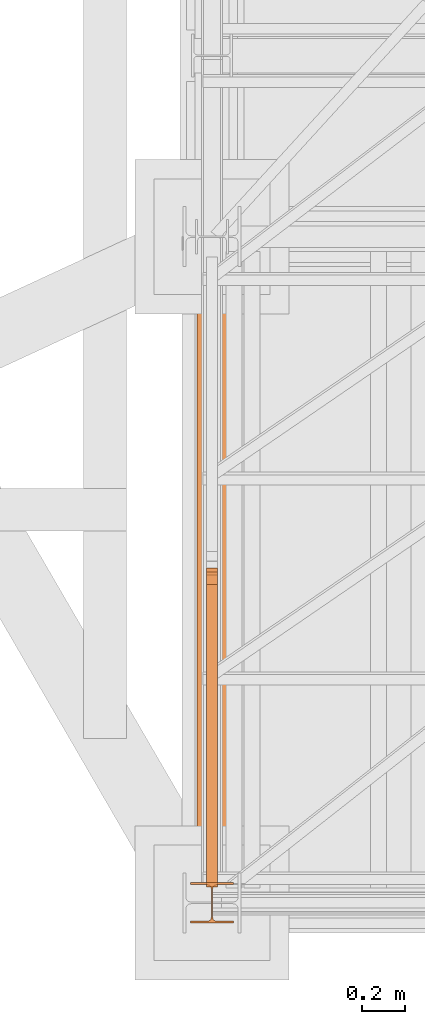
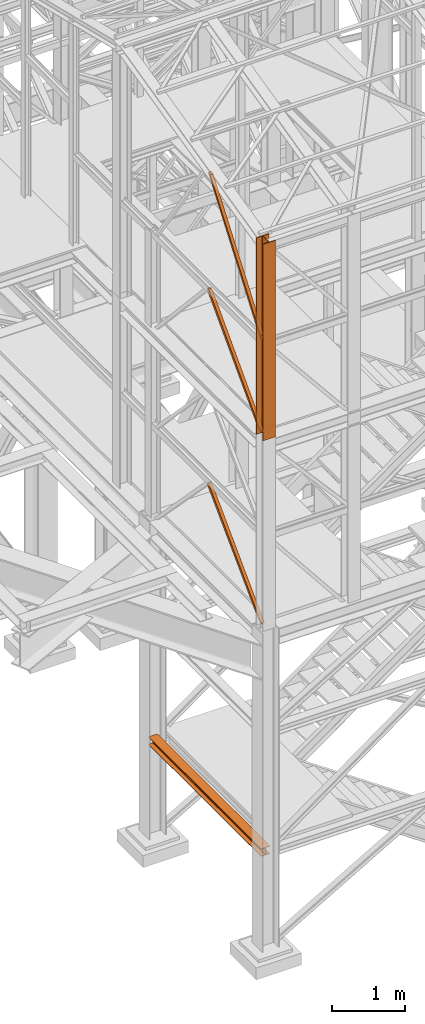
# One storey, part 3 of 208: 7 proxies.
"""IFC2X3 building model written with IfcOpenShell, lengths in millimetres."""

import ifcopenshell
import ifcopenshell.guid

model = None  # the IFC model being written
_history = None  # IfcOwnerHistory: only IFC2X3 demands one
_inside = {}  # id of a spatial element -> (the spatial element, [elements in it])
_under = {}  # id of a project, library or spatial element -> (it, [spatial elements below it])
_declared = {}  # id of a project -> (the project, [libraries it declares])
_typed = {}  # id of a type object -> (the type object, [elements of that type])
_made_of = {}  # id of a material, layer set ... -> (it, [elements and type objects made of it])


def new_model(schema):
    """Start an empty IFC model of exactly this schema.

    Asked for "IFC4X3", IfcOpenShell would pick the latest addendum, in which some entities
    have other attributes; the version numbers below select the first issue.
    IFC2X3 requires an IfcOwnerHistory on every rooted entity: one is made here for all.
    """
    global model, _history
    if schema == "IFC4X3":
        model = ifcopenshell.file(schema_version=(4, 3, 0, 0))
    else:
        model = ifcopenshell.file(schema=schema)
    _inside.clear()
    _under.clear()
    _declared.clear()
    _typed.clear()
    _made_of.clear()
    _history = None
    if model.schema == "IFC2X3":
        org = make("IfcOrganization", Name="unknown")
        user = make(
            "IfcPersonAndOrganization",
            ThePerson=make("IfcPerson", FamilyName="unknown"),
            TheOrganization=org,
        )
        app = make(
            "IfcApplication",
            ApplicationDeveloper=org,
            Version="unknown",
            ApplicationFullName="unknown",
            ApplicationIdentifier="unknown",
        )
        _history = make(
            "IfcOwnerHistory",
            OwningUser=user,
            OwningApplication=app,
            ChangeAction="ADDED",
            CreationDate=0,
        )
    return model


def make(cls, **values):
    """One entity of the class cls with the attributes given. An attribute that is None is left unset."""
    return model.create_entity(
        cls, **{name: value for name, value in values.items() if value is not None}
    )


def entity(cls, *values):
    """Any entity or typed value of the class cls, its attributes in the order of the schema. None: left unset."""
    e = model.create_entity(cls)
    for i, value in enumerate(values):
        if value is not None:
            e[i] = value
    return e


def rooted(cls, **values):
    """An entity with a GlobalId (a new one), such as an element, a storey or a relation."""
    return make(cls, GlobalId=ifcopenshell.guid.new(), OwnerHistory=_history, **values)


def si_unit(unit_type, name, prefix=None):
    """IfcSIUnit, for example si_unit("LENGTHUNIT", "METRE", prefix="MILLI")."""
    return make("IfcSIUnit", UnitType=unit_type, Prefix=prefix, Name=name)


def converted_unit(unit_type, name, factor, base, dimensions=None, offset=None):
    """IfcConversionBasedUnit, such as the inch: factor (a typed value) times the base unit."""
    return make(
        "IfcConversionBasedUnit"
        if offset is None
        else "IfcConversionBasedUnitWithOffset",
        ConversionOffset=offset,
        Dimensions=None
        if dimensions is None
        else entity("IfcDimensionalExponents", *dimensions),
        UnitType=unit_type,
        Name=name,
        ConversionFactor=make(
            "IfcMeasureWithUnit", ValueComponent=factor, UnitComponent=base
        ),
    )


def assignment(units):
    """IfcUnitAssignment: the units of a project."""
    return None if units is None else make("IfcUnitAssignment", Units=units)


def point(xyz):
    """IfcCartesianPoint."""
    return None if xyz is None else make("IfcCartesianPoint", Coordinates=xyz)


def direction(xyz):
    """IfcDirection."""
    return None if xyz is None else make("IfcDirection", DirectionRatios=xyz)


def frame(location, z_axis=None, x_axis=None):
    """IfcAxis2Placement3D, a coordinate frame: its origin and axes. An axis left out is left unset."""
    return make(
        "IfcAxis2Placement3D",
        Location=point(location),
        Axis=direction(z_axis),
        RefDirection=direction(x_axis),
    )


def origin():
    """The frame at (0, 0, 0) with its axes left unset."""
    return frame((0.0, 0.0, 0.0))


def origin_with_axes():
    """The frame at (0, 0, 0) with the z axis (0, 0, 1) and the x axis (1, 0, 0) written out."""
    return frame((0.0, 0.0, 0.0), z_axis=(0.0, 0.0, 1.0), x_axis=(1.0, 0.0, 0.0))


def place(relative_to, where):
    """IfcLocalPlacement: puts the frame where relative to a parent placement (None: the world)."""
    return make(
        "IfcLocalPlacement", PlacementRelTo=relative_to, RelativePlacement=where
    )


def context(
    kind, dimensions, precision=None, world=None, true_north=None, identifier=None
):
    """IfcGeometricRepresentationContext, for example the 3D "Model" context."""
    return make(
        "IfcGeometricRepresentationContext",
        ContextIdentifier=identifier,
        ContextType=kind,
        CoordinateSpaceDimension=dimensions,
        Precision=precision,
        WorldCoordinateSystem=world,
        TrueNorth=true_north,
    )


def subcontext(parent, identifier, kind, view, scale=None):
    """IfcGeometricRepresentationSubContext, for example "Body" below "Model"."""
    return make(
        "IfcGeometricRepresentationSubContext",
        ContextIdentifier=identifier,
        ContextType=kind,
        ParentContext=parent,
        TargetScale=scale,
        TargetView=view,
    )


def project(units=None, contexts=None):
    """IfcProject with its units and contexts."""
    return rooted(
        "IfcProject",
        Name="project",
        RepresentationContexts=contexts,
        UnitsInContext=assignment(units),
    )


def spatial(cls, under=None, at=None, **own):
    """A site, building, storey or space (cls), placed at a placement, below another one or the project."""
    s = rooted(cls, ObjectPlacement=at, **own)
    if under is not None:
        _under.setdefault(under.id(), (under, []))[1].append(s)
    return s


def faces_of(points, faces, orient=None, outer=None):
    """IfcFace entities. A face is a list of loops; a loop is a list of indices into points, from 0.

    orient and outer hold one flag for each loop. By default every Orientation is true, the
    first loop of a face is its IfcFaceOuterBound and the others are IfcFaceBound.
    """
    made = []
    for i, loops in enumerate(faces):
        bounds = []
        for j, loop in enumerate(loops):
            is_outer = j == 0 if outer is None else outer[i][j]
            bounds.append(
                make(
                    "IfcFaceOuterBound" if is_outer else "IfcFaceBound",
                    Bound=make("IfcPolyLoop", Polygon=[points[k] for k in loop]),
                    Orientation=True if orient is None else orient[i][j],
                )
            )
        made.append(make("IfcFace", Bounds=bounds))
    return made


def faceted_brep(points, faces, orient=None, outer=None, voids=None):
    """IfcFacetedBrep: a solid bounded by flat faces; with voids (closed shells), ...WithVoids."""
    shared = [point(p) for p in points]
    hull = make("IfcClosedShell", CfsFaces=faces_of(shared, faces, orient, outer))
    if voids is None:
        return make("IfcFacetedBrep", Outer=hull)
    return make(
        "IfcFacetedBrepWithVoids",
        Outer=hull,
        Voids=[
            make(cls, CfsFaces=faces_of(shared, fs, o, b)) for cls, fs, o, b in voids
        ],
    )


def shape(context_of_items, identifier, shape_type, items):
    """IfcShapeRepresentation: the items that make up one representation, for example the "Body"."""
    return make(
        "IfcShapeRepresentation",
        ContextOfItems=context_of_items,
        RepresentationIdentifier=identifier,
        RepresentationType=shape_type,
        Items=items,
    )


def made_of(thing, what):
    """Note that an element or type object is made of a material, layer set ...; save() writes the relation."""
    if what is not None:
        _made_of.setdefault(what.id(), (what, []))[1].append(thing)
    return thing


def element(
    cls,
    number,
    at=None,
    inside=None,
    cuts=None,
    type_object=None,
    material=None,
    context=None,
    identifier="Body",
    shape_type=None,
    held_by="IfcProductDefinitionShape",
    body=None,
    shapes=None,
    **own,
):
    """One element of the class cls, such as IfcWall. Its Tag is "e" and its number.

    at: its placement. inside: the storey or other place that contains it. cuts: it is an
    opening in that element (IfcRelVoidsElement). A single representation is given by context,
    identifier, shape_type and body (its items); several are given by shapes. held_by: the class
    of the entity that holds the representations. save() writes the other relations.
    """
    e = rooted(cls, Tag="e%d" % number, ObjectPlacement=at, **own)
    if body is not None:
        shapes = [shape(context, identifier, shape_type, body)]
    if shapes is not None:
        e.Representation = make(held_by, Representations=shapes)
    if inside is not None:
        _inside.setdefault(inside.id(), (inside, []))[1].append(e)
    if cuts is not None:
        rooted(
            "IfcRelVoidsElement", RelatingBuildingElement=cuts, RelatedOpeningElement=e
        )
    if type_object is not None:
        _typed.setdefault(type_object.id(), (type_object, []))[1].append(e)
    return made_of(e, material)


def aggregate(whole, parts):
    """IfcRelAggregates: a whole, such as a stair, and the parts it consists of."""
    return rooted("IfcRelAggregates", RelatingObject=whole, RelatedObjects=parts)


def save(model, path):
    """Write the relations noted so far, then the file.

    IfcRelAggregates (storeys below a building ...), IfcRelContainedInSpatialStructure (elements
    in a storey), IfcRelDefinesByType, IfcRelAssociatesMaterial and IfcRelDeclares: one each for
    every whole, place, type object, material and project.
    """
    for whole, parts in _under.values():
        aggregate(whole, parts)
    for where, things in _inside.values():
        rooted(
            "IfcRelContainedInSpatialStructure",
            RelatedElements=things,
            RelatingStructure=where,
        )
    for kind, things in _typed.values():
        rooted("IfcRelDefinesByType", RelatedObjects=things, RelatingType=kind)
    for what, things in _made_of.values():
        rooted("IfcRelAssociatesMaterial", RelatedObjects=things, RelatingMaterial=what)
    for by, libraries in _declared.values():
        rooted("IfcRelDeclares", RelatingContext=by, RelatedDefinitions=libraries)
    model.write(path)


model = new_model("IFC2X3")

# Units and contexts
model_context = context("Model", 3, precision=1e-05, world=origin())
plan_context = context("Plan", 3, precision=1e-05, world=origin())
body_context = subcontext(model_context, "Body", "Model", "MODEL_VIEW")
ifc_project = project(units=[si_unit("LENGTHUNIT", "METRE", prefix="MILLI"), converted_unit("PLANEANGLEUNIT", "DEGREE", entity("IfcPlaneAngleMeasure", 0.0174532925199433), si_unit("PLANEANGLEUNIT", "RADIAN"), dimensions=[0, 0, 0, 0, 0, 0, 0]), si_unit("AREAUNIT", "SQUARE_METRE"), si_unit("VOLUMEUNIT", "CUBIC_METRE")], contexts=[model_context, plan_context])

# Building, storey
building_placement = place(None, origin())
building = spatial("IfcBuilding", under=ifc_project, at=building_placement, CompositionType="COMPLEX")
storey_placement = place(building_placement, origin_with_axes())
storey = spatial("IfcBuildingStorey", under=building, at=storey_placement, Name="Geschoss", CompositionType="ELEMENT")

# Proxies
proxy_1_placement = place(storey_placement, frame((1128.922936086903, -25168.5743901279, 1433.489998909946), z_axis=(0.0, 0.0, 1.0), x_axis=(1.0, 0.0, 0.0)))
element("IfcBuildingElementProxy", 1, at=proxy_1_placement, inside=storey, context=body_context, shape_type="Brep", body=[
    faceted_brep([(0.01000000000067303, 3102.009999620019, 8.510002324581137), (0.01000000000067303, 3102.009999620019, 0.009999999999990905), (140.0100005960469, 3102.009999620019, 0.009999999999990905), (140.0100005960469, 3102.009999620019, 8.510002324581137), (84.76000038743086, 3102.009999620019, 8.510002324581137), (78.54945996612378, 3102.009999620019, 9.753034839630118), (74.00303279817172, 3102.009999620019, 14.2994648015499), (72.76000051595338, 3102.009999620019, 20.51000429153442), (72.76000051595338, 3102.009999620019, 112.5100007450581), (74.00303279817172, 3102.009999620019, 118.7205402350426), (78.54945996612378, 3102.009999620019, 123.2669664716721), (84.76000038743086, 3102.009999620019, 124.509998986721), (140.0100005960469, 3102.009999620019, 124.509998986721), (140.0100005960469, 3102.009999620019, 133.0100013113022), (0.01000000000067303, 3102.009999620019, 133.0100013113022), (0.01000000000067303, 3102.009999620019, 124.509998986721), (55.26000020861693, 3102.009999620019, 124.509998986721), (61.47054062992402, 3102.009999620019, 123.2669664716721), (66.01696779787608, 3102.009999620019, 118.7205402350426), (67.26000008009441, 3102.009999620019, 112.5100007450581), (67.26000008009441, 3102.009999620019, 20.51000429153442), (66.01696779787608, 3102.009999620019, 14.2994648015499), (61.47054062992402, 3102.009999620019, 9.753034839630118), (55.26000020861693, 3102.009999620019, 8.510002324581137), (0.01000000000067303, 3102.009999620019, 0.009999999999990905), (0.01000000000067303, 3102.009999620019, 8.510002324581137), (0.01000000000021828, 0.00999999999839929, 8.510002324581137), (0.01000000000021828, 0.00999999999839929, 0.009999999999990905), (140.0100005960469, 3102.009999620019, 0.009999999999990905), (0.01000000000067303, 3102.009999620019, 0.009999999999990905), (0.01000000000021828, 0.00999999999839929, 0.009999999999990905), (140.0100005960467, 0.00999999999839929, 0.009999999999990905), (140.0100005960469, 3102.009999620019, 8.510002324581137), (140.0100005960469, 3102.009999620019, 0.009999999999990905), (140.0100005960467, 0.00999999999839929, 0.009999999999990905), (140.0100005960467, 0.00999999999839929, 8.510002324581137), (84.76000038743086, 3102.009999620019, 8.510002324581137), (140.0100005960469, 3102.009999620019, 8.510002324581137), (140.0100005960467, 0.00999999999839929, 8.510002324581137), (84.76000038743041, 0.00999999999839929, 8.510002324581137), (78.54945996612378, 3102.009999620019, 9.753034839630118), (84.76000038743086, 3102.009999620019, 8.510002324581137), (84.76000038743041, 0.00999999999839929, 8.510002324581137), (78.54945996612332, 0.00999999999839929, 9.753034839630118), (74.00303279817172, 3102.009999620019, 14.2994648015499), (78.54945996612378, 3102.009999620019, 9.753034839630118), (78.54945996612332, 0.00999999999839929, 9.753034839630118), (74.00303279817126, 0.00999999999839929, 14.2994648015499), (72.76000051595338, 3102.009999620019, 20.51000429153442), (74.00303279817172, 3102.009999620019, 14.2994648015499), (74.00303279817126, 0.00999999999839929, 14.2994648015499), (72.76000051595292, 0.00999999999839929, 20.51000429153442), (72.76000051595338, 3102.009999620019, 112.5100007450581), (72.76000051595338, 3102.009999620019, 20.51000429153442), (72.76000051595292, 0.00999999999839929, 20.51000429153442), (72.76000051595292, 0.00999999999839929, 112.5100007450581), (74.00303279817172, 3102.009999620019, 118.7205402350426), (72.76000051595338, 3102.009999620019, 112.5100007450581), (72.76000051595292, 0.00999999999839929, 112.5100007450581), (74.00303279817126, 0.00999999999839929, 118.7205402350426), (78.54945996612378, 3102.009999620019, 123.2669664716721), (74.00303279817172, 3102.009999620019, 118.7205402350426), (74.00303279817126, 0.00999999999839929, 118.7205402350426), (78.54945996612332, 0.00999999999839929, 123.2669664716721), (84.76000038743086, 3102.009999620019, 124.509998986721), (78.54945996612378, 3102.009999620019, 123.2669664716721), (78.54945996612332, 0.00999999999839929, 123.2669664716721), (84.76000038743041, 0.00999999999839929, 124.509998986721), (140.0100005960469, 3102.009999620019, 124.509998986721), (84.76000038743086, 3102.009999620019, 124.509998986721), (84.76000038743041, 0.00999999999839929, 124.509998986721), (140.0100005960467, 0.00999999999839929, 124.509998986721), (140.0100005960469, 3102.009999620019, 133.0100013113022), (140.0100005960469, 3102.009999620019, 124.509998986721), (140.0100005960467, 0.00999999999839929, 124.509998986721), (140.0100005960467, 0.00999999999839929, 133.0100013113022), (0.01000000000067303, 3102.009999620019, 133.0100013113022), (140.0100005960469, 3102.009999620019, 133.0100013113022), (140.0100005960467, 0.00999999999839929, 133.0100013113022), (0.01000000000021828, 0.00999999999839929, 133.0100013113022), (0.01000000000067303, 3102.009999620019, 124.509998986721), (0.01000000000067303, 3102.009999620019, 133.0100013113022), (0.01000000000021828, 0.00999999999839929, 133.0100013113022), (0.01000000000021828, 0.00999999999839929, 124.509998986721), (55.26000020861693, 3102.009999620019, 124.509998986721), (0.01000000000067303, 3102.009999620019, 124.509998986721), (0.01000000000021828, 0.00999999999839929, 124.509998986721), (55.26000020861648, 0.00999999999839929, 124.509998986721), (61.47054062992402, 3102.009999620019, 123.2669664716721), (55.26000020861693, 3102.009999620019, 124.509998986721), (55.26000020861648, 0.00999999999839929, 124.509998986721), (61.47054062992356, 0.00999999999839929, 123.2669664716721), (66.01696779787608, 3102.009999620019, 118.7205402350426), (61.47054062992402, 3102.009999620019, 123.2669664716721), (61.47054062992356, 0.00999999999839929, 123.2669664716721), (66.01696779787562, 0.00999999999839929, 118.7205402350426), (67.26000008009441, 3102.009999620019, 112.5100007450581), (66.01696779787608, 3102.009999620019, 118.7205402350426), (66.01696779787562, 0.00999999999839929, 118.7205402350426), (67.26000008009396, 0.00999999999839929, 112.5100007450581), (67.26000008009441, 3102.009999620019, 20.51000429153442), (67.26000008009441, 3102.009999620019, 112.5100007450581), (67.26000008009396, 0.00999999999839929, 112.5100007450581), (67.26000008009396, 0.00999999999839929, 20.51000429153442), (66.01696779787608, 3102.009999620019, 14.2994648015499), (67.26000008009441, 3102.009999620019, 20.51000429153442), (67.26000008009396, 0.00999999999839929, 20.51000429153442), (66.01696779787562, 0.00999999999839929, 14.2994648015499), (61.47054062992402, 3102.009999620019, 9.753034839630118), (66.01696779787608, 3102.009999620019, 14.2994648015499), (66.01696779787562, 0.00999999999839929, 14.2994648015499), (61.47054062992356, 0.00999999999839929, 9.753034839630118), (55.26000020861693, 3102.009999620019, 8.510002324581137), (61.47054062992402, 3102.009999620019, 9.753034839630118), (61.47054062992356, 0.00999999999839929, 9.753034839630118), (55.26000020861648, 0.00999999999839929, 8.510002324581137), (0.01000000000067303, 3102.009999620019, 8.510002324581137), (55.26000020861693, 3102.009999620019, 8.510002324581137), (55.26000020861648, 0.00999999999839929, 8.510002324581137), (0.01000000000021828, 0.00999999999839929, 8.510002324581137), (0.01000000000021828, 0.00999999999839929, 8.510002324581137), (55.26000020861648, 0.00999999999839929, 8.510002324581137), (61.47054062992356, 0.00999999999839929, 9.753034839630118), (66.01696779787562, 0.00999999999839929, 14.2994648015499), (67.26000008009396, 0.00999999999839929, 20.51000429153442), (67.26000008009396, 0.00999999999839929, 112.5100007450581), (66.01696779787562, 0.00999999999839929, 118.7205402350426), (61.47054062992356, 0.00999999999839929, 123.2669664716721), (55.26000020861648, 0.00999999999839929, 124.509998986721), (0.01000000000021828, 0.00999999999839929, 124.509998986721), (0.01000000000021828, 0.00999999999839929, 133.0100013113022), (140.0100005960467, 0.00999999999839929, 133.0100013113022), (140.0100005960467, 0.00999999999839929, 124.509998986721), (84.76000038743041, 0.00999999999839929, 124.509998986721), (78.54945996612332, 0.00999999999839929, 123.2669664716721), (74.00303279817126, 0.00999999999839929, 118.7205402350426), (72.76000051595292, 0.00999999999839929, 112.5100007450581), (72.76000051595292, 0.00999999999839929, 20.51000429153442), (74.00303279817126, 0.00999999999839929, 14.2994648015499), (78.54945996612332, 0.00999999999839929, 9.753034839630118), (84.76000038743041, 0.00999999999839929, 8.510002324581137), (140.0100005960467, 0.00999999999839929, 8.510002324581137), (140.0100005960467, 0.00999999999839929, 0.009999999999990905), (0.01000000000021828, 0.00999999999839929, 0.009999999999990905)], [[[0, 1, 2, 3, 4, 5, 6, 7, 8, 9, 10, 11, 12, 13, 14, 15, 16, 17, 18, 19, 20, 21, 22, 23]], [[24, 25, 26, 27]], [[28, 29, 30, 31]], [[32, 33, 34, 35]], [[36, 37, 38, 39]], [[40, 41, 42, 43]], [[44, 45, 46, 47]], [[48, 49, 50, 51]], [[52, 53, 54, 55]], [[56, 57, 58, 59]], [[60, 61, 62, 63]], [[64, 65, 66, 67]], [[68, 69, 70, 71]], [[72, 73, 74, 75]], [[76, 77, 78, 79]], [[80, 81, 82, 83]], [[84, 85, 86, 87]], [[88, 89, 90, 91]], [[92, 93, 94, 95]], [[96, 97, 98, 99]], [[100, 101, 102, 103]], [[104, 105, 106, 107]], [[108, 109, 110, 111]], [[112, 113, 114, 115]], [[116, 117, 118, 119]], [[120, 121, 122, 123, 124, 125, 126, 127, 128, 129, 130, 131, 132, 133, 134, 135, 136, 137, 138, 139, 140, 141, 142, 143]]], orient=[[False], [False], [False], [False], [False], [False], [False], [False], [False], [False], [False], [False], [False], [False], [False], [False], [False], [False], [False], [False], [False], [False], [False], [False], [False], [False]]),
])
proxy_2_placement = place(storey_placement, frame((1098.254967038543, -25267.57439657637, 8484.990002086155), z_axis=(0.0, 0.0, 1.0), x_axis=(1.0, 0.0, 0.0)))
element("IfcBuildingElementProxy", 2, at=proxy_2_placement, inside=storey, context=body_context, shape_type="Brep", body=[
    faceted_brep([(0.009999999999990905, 190.010021192018, 3300.392426689976), (200.0100029802322, 190.010021192018, 3300.392426689976), (200.0100029802322, 180.0100232781806, 3300.392426689976), (121.2600035762787, 180.0100158276, 3300.392426689976), (111.9441915473342, 178.1454707803168, 3300.392426689976), (105.1245498640835, 171.3258277000823, 3300.392426689976), (103.2600015571713, 162.0100166024604, 3300.392426689976), (103.2600015571713, 28.01000581401968, 3300.392426689976), (105.1245498640835, 18.69419471639776, 3300.392426689976), (111.9441915473342, 11.87455163616323, 3300.392426689976), (121.2600035762787, 10.01000658888006, 3300.392426689976), (200.0100029802322, 10.01000658888006, 3300.392426689976), (200.0100029802322, 0.01000867504262715, 3300.392426689976), (0.009999999999990905, 0.01000867504262715, 3300.392426689976), (0.009999999999990905, 10.01000658888006, 3300.392426689976), (78.75999940395354, 10.01000658888006, 3300.392426689976), (88.07581143289804, 11.87455163616323, 3300.392426689976), (94.8954531161487, 18.69419471639776, 3300.392426689976), (96.76000142306088, 28.01000581401968, 3300.392426689976), (96.76000142306088, 162.0100166024604, 3300.392426689976), (94.8954531161487, 171.3258277000823, 3300.392426689976), (88.07581143289804, 178.1454707803168, 3300.392426689976), (78.75999940395354, 180.0100158276, 3300.392426689976), (0.009999999999990905, 180.0100232781806, 3300.392426689976), (200.0100029802322, 190.010021192018, 3300.392426689976), (0.009999999999990905, 190.010021192018, 3300.392426689976), (0.009999999999990905, 190.0100125169738, 0.01000000000021828), (200.0100029802322, 190.0100125169738, 0.01000000000021828), (200.0100029802322, 180.0100232781806, 3300.392426689976), (200.0100029802322, 190.010021192018, 3300.392426689976), (200.0100029802322, 190.0100125169738, 0.01000000000021828), (200.0100029802322, 180.0100146031364, 0.01000000000021828), (121.2600035762787, 180.0100158276, 3300.392426689976), (200.0100029802322, 180.0100232781806, 3300.392426689976), (200.0100029802322, 180.0100146031364, 0.01000000000021828), (121.2600035762787, 180.0100071525558, 0.01000000000021828), (111.9441915473342, 178.1454707803168, 3300.392426689976), (121.2600035762787, 180.0100158276, 3300.392426689976), (121.2600035762787, 180.0100071525558, 0.01000000000021828), (111.9441915473342, 178.1454621052726, 0.01000000000021828), (105.1245498640835, 171.3258277000823, 3300.392426689976), (111.9441915473342, 178.1454707803168, 3300.392426689976), (111.9441915473342, 178.1454621052726, 0.01000000000021828), (105.1245498640835, 171.3258190250381, 0.01000000000021828), (103.2600015571713, 162.0100166024604, 3300.392426689976), (105.1245498640835, 171.3258277000823, 3300.392426689976), (105.1245498640835, 171.3258190250381, 0.01000000000021828), (103.2600015571713, 162.0100079274162, 0.01000000000021828), (103.2600015571713, 28.01000581401968, 3300.392426689976), (103.2600015571713, 162.0100166024604, 3300.392426689976), (103.2600015571713, 162.0100079274162, 0.01000000000021828), (103.2600015571713, 28.00999713897545, 0.01000000000021828), (105.1245498640835, 18.69419471639776, 3300.392426689976), (103.2600015571713, 28.01000581401968, 3300.392426689976), (103.2600015571713, 28.00999713897545, 0.01000000000021828), (105.1245498640835, 18.69418604135353, 0.01000000000021828), (111.9441915473342, 11.87455163616323, 3300.392426689976), (105.1245498640835, 18.69419471639776, 3300.392426689976), (105.1245498640835, 18.69418604135353, 0.01000000000021828), (111.9441915473342, 11.87454296111901, 0.01000000000021828), (121.2600035762787, 10.01000658888006, 3300.392426689976), (111.9441915473342, 11.87455163616323, 3300.392426689976), (111.9441915473342, 11.87454296111901, 0.01000000000021828), (121.2600035762787, 10.00999791383583, 0.01000000000021828), (200.0100029802322, 10.01000658888006, 3300.392426689976), (121.2600035762787, 10.01000658888006, 3300.392426689976), (121.2600035762787, 10.00999791383583, 0.01000000000021828), (200.0100029802322, 10.00999791383583, 0.01000000000021828), (200.0100029802322, 0.01000867504262715, 3300.392426689976), (200.0100029802322, 10.01000658888006, 3300.392426689976), (200.0100029802322, 10.00999791383583, 0.01000000000021828), (200.0100029802322, 0.00999999999839929, 0.01000000000021828), (0.009999999999990905, 0.01000867504262715, 3300.392426689976), (200.0100029802322, 0.01000867504262715, 3300.392426689976), (200.0100029802322, 0.00999999999839929, 0.01000000000021828), (0.009999999999990905, 0.00999999999839929, 0.01000000000021828), (0.009999999999990905, 10.01000658888006, 3300.392426689976), (0.009999999999990905, 0.01000867504262715, 3300.392426689976), (0.009999999999990905, 0.00999999999839929, 0.01000000000021828), (0.009999999999990905, 10.00999791383583, 0.01000000000021828), (78.75999940395354, 10.01000658888006, 3300.392426689976), (0.009999999999990905, 10.01000658888006, 3300.392426689976), (0.009999999999990905, 10.00999791383583, 0.01000000000021828), (78.75999940395354, 10.00999791383583, 0.01000000000021828), (88.07581143289804, 11.87455163616323, 3300.392426689976), (78.75999940395354, 10.01000658888006, 3300.392426689976), (78.75999940395354, 10.00999791383583, 0.01000000000021828), (88.07581143289804, 11.87454296111901, 0.01000000000021828), (94.8954531161487, 18.69419471639776, 3300.392426689976), (88.07581143289804, 11.87455163616323, 3300.392426689976), (88.07581143289804, 11.87454296111901, 0.01000000000021828), (94.8954531161487, 18.69418604135353, 0.01000000000021828), (96.76000142306088, 28.01000581401968, 3300.392426689976), (94.8954531161487, 18.69419471639776, 3300.392426689976), (94.8954531161487, 18.69418604135353, 0.01000000000021828), (96.76000142306088, 28.00999713897545, 0.01000000000021828), (96.76000142306088, 162.0100166024604, 3300.392426689976), (96.76000142306088, 28.01000581401968, 3300.392426689976), (96.76000142306088, 28.00999713897545, 0.01000000000021828), (96.76000142306088, 162.0100079274162, 0.01000000000021828), (94.8954531161487, 171.3258277000823, 3300.392426689976), (96.76000142306088, 162.0100166024604, 3300.392426689976), (96.76000142306088, 162.0100079274162, 0.01000000000021828), (94.8954531161487, 171.3258190250381, 0.01000000000021828), (88.07581143289804, 178.1454707803168, 3300.392426689976), (94.8954531161487, 171.3258277000823, 3300.392426689976), (94.8954531161487, 171.3258190250381, 0.01000000000021828), (88.07581143289804, 178.1454621052726, 0.01000000000021828), (78.75999940395354, 180.0100158276, 3300.392426689976), (88.07581143289804, 178.1454707803168, 3300.392426689976), (88.07581143289804, 178.1454621052726, 0.01000000000021828), (78.75999940395354, 180.0100071525558, 0.01000000000021828), (0.009999999999990905, 180.0100232781806, 3300.392426689976), (78.75999940395354, 180.0100158276, 3300.392426689976), (78.75999940395354, 180.0100071525558, 0.01000000000021828), (0.009999999999990905, 180.0100146031364, 0.01000000000021828), (0.009999999999990905, 190.010021192018, 3300.392426689976), (0.009999999999990905, 180.0100232781806, 3300.392426689976), (0.009999999999990905, 180.0100146031364, 0.01000000000021828), (0.009999999999990905, 190.0100125169738, 0.01000000000021828), (0.009999999999990905, 190.0100125169738, 0.01000000000021828), (0.009999999999990905, 180.0100146031364, 0.01000000000021828), (78.75999940395354, 180.0100071525558, 0.01000000000021828), (88.07581143289804, 178.1454621052726, 0.01000000000021828), (94.8954531161487, 171.3258190250381, 0.01000000000021828), (96.76000142306088, 162.0100079274162, 0.01000000000021828), (96.76000142306088, 28.00999713897545, 0.01000000000021828), (94.8954531161487, 18.69418604135353, 0.01000000000021828), (88.07581143289804, 11.87454296111901, 0.01000000000021828), (78.75999940395354, 10.00999791383583, 0.01000000000021828), (0.009999999999990905, 10.00999791383583, 0.01000000000021828), (0.009999999999990905, 0.00999999999839929, 0.01000000000021828), (200.0100029802322, 0.00999999999839929, 0.01000000000021828), (200.0100029802322, 10.00999791383583, 0.01000000000021828), (121.2600035762787, 10.00999791383583, 0.01000000000021828), (111.9441915473342, 11.87454296111901, 0.01000000000021828), (105.1245498640835, 18.69418604135353, 0.01000000000021828), (103.2600015571713, 28.00999713897545, 0.01000000000021828), (103.2600015571713, 162.0100079274162, 0.01000000000021828), (105.1245498640835, 171.3258190250381, 0.01000000000021828), (111.9441915473342, 178.1454621052726, 0.01000000000021828), (121.2600035762787, 180.0100071525558, 0.01000000000021828), (200.0100029802322, 180.0100146031364, 0.01000000000021828), (200.0100029802322, 190.0100125169738, 0.01000000000021828)], [[[0, 1, 2, 3, 4, 5, 6, 7, 8, 9, 10, 11, 12, 13, 14, 15, 16, 17, 18, 19, 20, 21, 22, 23]], [[24, 25, 26, 27]], [[28, 29, 30, 31]], [[32, 33, 34, 35]], [[36, 37, 38, 39]], [[40, 41, 42, 43]], [[44, 45, 46, 47]], [[48, 49, 50, 51]], [[52, 53, 54, 55]], [[56, 57, 58, 59]], [[60, 61, 62, 63]], [[64, 65, 66, 67]], [[68, 69, 70, 71]], [[72, 73, 74, 75]], [[76, 77, 78, 79]], [[80, 81, 82, 83]], [[84, 85, 86, 87]], [[88, 89, 90, 91]], [[92, 93, 94, 95]], [[96, 97, 98, 99]], [[100, 101, 102, 103]], [[104, 105, 106, 107]], [[108, 109, 110, 111]], [[112, 113, 114, 115]], [[116, 117, 118, 119]], [[120, 121, 122, 123, 124, 125, 126, 127, 128, 129, 130, 131, 132, 133, 134, 135, 136, 137, 138, 139, 140, 141, 142, 143]]], orient=[[False], [False], [False], [False], [False], [False], [False], [False], [False], [False], [False], [False], [False], [False], [False], [False], [False], [False], [False], [False], [False], [False], [False], [False], [False], [False]]),
])
proxy_3_placement = place(storey_placement, frame((1173.25497001878, -25097.52533058902, 5284.990005364415), z_axis=(0.0, 0.0, 1.0), x_axis=(1.0, 0.0, 0.0)))
element("IfcBuildingElementProxy", 3, at=proxy_3_placement, inside=storey, context=body_context, shape_type="Brep", body=[
    faceted_brep([(0.0100000000009004, 1487.961249093536, 1429.098575334028), (0.009999999999990905, 63.79741231748267, 0.01000000000021828), (50.01000074505805, 63.79741231748267, 0.01000000000021828), (50.01000074505896, 1487.961249093536, 1429.098575334027), (50.01000074505896, 1455.239949618484, 1474.917439180826), (50.01000074505896, 1487.540655406407, 1475.009993890528), (50.01000074505896, 1487.961249093536, 1429.098575334027), (50.01000074505805, 63.79741231748267, 0.01000000000021828), (50.01000074505805, 0.00999999999839929, 0.01000000000021828), (0.0100000000009004, 1455.239949618484, 1474.917439180826), (50.01000074505896, 1455.239949618484, 1474.917439180826), (50.01000074505805, 0.00999999999839929, 0.01000000000021828), (0.009999999999990905, 0.00999999999839929, 0.01000000000021828), (0.0100000000009004, 1487.540655406407, 1475.009993890528), (0.0100000000009004, 1455.239949618484, 1474.917439180826), (0.009999999999990905, 0.00999999999839929, 0.01000000000021828), (0.009999999999990905, 63.79741231748267, 0.01000000000021828), (0.0100000000009004, 1487.961249093536, 1429.098575334028), (50.01000074505896, 1487.540655406407, 1475.009993890528), (50.01000074505896, 1455.239949618484, 1474.917439180826), (0.0100000000009004, 1455.239949618484, 1474.917439180826), (0.0100000000009004, 1487.540655406407, 1475.009993890528), (50.01000074505896, 1487.961249093536, 1429.098575334027), (50.01000074505896, 1487.540655406407, 1475.009993890528), (0.0100000000009004, 1487.540655406407, 1475.009993890528), (0.0100000000009004, 1487.961249093536, 1429.098575334028), (0.009999999999990905, 63.79741231748267, 0.01000000000021828), (0.009999999999990905, 0.00999999999839929, 0.01000000000021828), (50.01000074505805, 0.00999999999839929, 0.01000000000021828), (50.01000074505805, 63.79741231748267, 0.01000000000021828)], [[[0, 1, 2, 3]], [[4, 5, 6, 7, 8]], [[9, 10, 11, 12]], [[13, 14, 15, 16, 17]], [[18, 19, 20, 21]], [[22, 23, 24, 25]], [[26, 27, 28, 29]]], orient=[[False], [False], [False], [False], [False], [False], [False]]),
])
proxy_4_placement = place(storey_placement, frame((1173.254970018778, -25097.52533058902, 8484.990002086159), z_axis=(0.0, 0.0, 1.0), x_axis=(1.0, 0.0, 0.0)))
element("IfcBuildingElementProxy", 4, at=proxy_4_placement, inside=storey, context=body_context, shape_type="Brep", body=[
    faceted_brep([(0.0100000000009004, 1487.777252844244, 1497.729951931144), (0.009999999999990905, 63.79741231748267, 0.00999999999839929), (50.01000074505805, 63.79741231748267, 0.00999999999839929), (50.01000074505896, 1487.777252844244, 1497.72995193114), (50.01000074505896, 1455.239949618484, 1542.509998658894), (50.01000074505896, 1487.961138278424, 1542.602553368595), (50.01000074505896, 1487.777252844244, 1497.72995193114), (50.01000074505805, 63.79741231748267, 0.00999999999839929), (50.01000074505805, 0.00999999999839929, 0.00999999999839929), (0.0100000000009004, 1455.239949618484, 1542.509998658894), (50.01000074505896, 1455.239949618484, 1542.509998658894), (50.01000074505805, 0.00999999999839929, 0.00999999999839929), (0.009999999999990905, 0.00999999999839929, 0.00999999999839929), (0.0100000000009004, 1487.961138278424, 1542.602553368595), (0.0100000000009004, 1455.239949618484, 1542.509998658894), (0.009999999999990905, 0.00999999999839929, 0.00999999999839929), (0.009999999999990905, 63.79741231748267, 0.00999999999839929), (0.0100000000009004, 1487.777252844244, 1497.729951931144), (50.01000074505896, 1487.961138278424, 1542.602553368595), (50.01000074505896, 1455.239949618484, 1542.509998658894), (0.0100000000009004, 1455.239949618484, 1542.509998658894), (0.0100000000009004, 1487.961138278424, 1542.602553368595), (50.01000074505896, 1487.777252844244, 1497.72995193114), (50.01000074505896, 1487.961138278424, 1542.602553368595), (0.0100000000009004, 1487.961138278424, 1542.602553368595), (0.0100000000009004, 1487.777252844244, 1497.729951931144), (0.009999999999990905, 63.79741231748267, 0.00999999999839929), (0.009999999999990905, 0.00999999999839929, 0.00999999999839929), (50.01000074505805, 0.00999999999839929, 0.00999999999839929), (50.01000074505805, 63.79741231748267, 0.00999999999839929)], [[[0, 1, 2, 3]], [[4, 5, 6, 7, 8]], [[9, 10, 11, 12]], [[13, 14, 15, 16, 17]], [[18, 19, 20, 21]], [[22, 23, 24, 25]], [[26, 27, 28, 29]]], orient=[[False], [False], [False], [False], [False], [False], [False]]),
])
proxy_5_placement = place(storey_placement, frame((1173.254970018778, -25097.52533058902, 8484.990002086159), z_axis=(0.0, 0.0, 1.0), x_axis=(1.0, 0.0, 0.0)))
element("IfcBuildingElementProxy", 5, at=proxy_5_placement, inside=storey, context=body_context, shape_type="Brep", body=[
    faceted_brep([(0.0100000000009004, 1487.777252844244, 1497.729951931144), (0.009999999999990905, 63.79741231748267, 0.00999999999839929), (50.01000074505805, 63.79741231748267, 0.00999999999839929), (50.01000074505896, 1487.777252844244, 1497.72995193114), (50.01000074505896, 1455.239949618484, 1542.509998658894), (50.01000074505896, 1487.961138278424, 1542.602553368595), (50.01000074505896, 1487.777252844244, 1497.72995193114), (50.01000074505805, 63.79741231748267, 0.00999999999839929), (50.01000074505805, 0.00999999999839929, 0.00999999999839929), (0.0100000000009004, 1455.239949618484, 1542.509998658894), (50.01000074505896, 1455.239949618484, 1542.509998658894), (50.01000074505805, 0.00999999999839929, 0.00999999999839929), (0.009999999999990905, 0.00999999999839929, 0.00999999999839929), (0.0100000000009004, 1487.961138278424, 1542.602553368595), (0.0100000000009004, 1455.239949618484, 1542.509998658894), (0.009999999999990905, 0.00999999999839929, 0.00999999999839929), (0.009999999999990905, 63.79741231748267, 0.00999999999839929), (0.0100000000009004, 1487.777252844244, 1497.729951931144), (50.01000074505896, 1487.961138278424, 1542.602553368595), (50.01000074505896, 1455.239949618484, 1542.509998658894), (0.0100000000009004, 1455.239949618484, 1542.509998658894), (0.0100000000009004, 1487.961138278424, 1542.602553368595), (50.01000074505896, 1487.777252844244, 1497.72995193114), (50.01000074505896, 1487.961138278424, 1542.602553368595), (0.0100000000009004, 1487.961138278424, 1542.602553368595), (0.0100000000009004, 1487.777252844244, 1497.729951931144), (0.009999999999990905, 63.79741231748267, 0.00999999999839929), (0.009999999999990905, 0.00999999999839929, 0.00999999999839929), (50.01000074505805, 0.00999999999839929, 0.00999999999839929), (50.01000074505805, 63.79741231748267, 0.00999999999839929)], [[[0, 1, 2, 3]], [[4, 5, 6, 7, 8]], [[9, 10, 11, 12]], [[13, 14, 15, 16, 17]], [[18, 19, 20, 21]], [[22, 23, 24, 25]], [[26, 27, 28, 29]]], orient=[[False], [False], [False], [False], [False], [False], [False]]),
])
proxy_6_placement = place(storey_placement, frame((1173.254970018778, -25077.57438405939, 10042.31043759707), z_axis=(0.0, 0.0, 1.0), x_axis=(1.0, 0.0, 0.0)))
element("IfcBuildingElementProxy", 6, at=proxy_6_placement, inside=storey, context=body_context, shape_type="Brep", body=[
    faceted_brep([(50.01000074505896, 0.01000000000567525, 71.50990716364868), (0.0100000000009004, 0.01000000000567525, 71.50990716364868), (0.009999999999990905, 1392.314909891044, 1924.512375451423), (50.01000074505805, 1392.314909891044, 1924.512375451423), (50.01000074505896, 7.23099057815125, 0.1025547097015078), (50.01000074505896, 0.01000000000203727, 0.01000000000021828), (50.01000074505896, 0.01000000000567525, 71.50990716364868), (50.01000074505805, 1392.314909891044, 1924.512375451423), (50.01000074505805, 1449.983879904732, 1938.510406099498), (0.0100000000009004, 7.23099057815125, 0.1025547097015078), (50.01000074505896, 7.23099057815125, 0.1025547097015078), (50.01000074505805, 1449.983879904732, 1938.510406099498), (0.009999999999990905, 1449.983879904732, 1938.510406099496), (0.0100000000009004, 0.01000000000567525, 71.50990716364868), (0.0100000000009004, 0.01000000000203727, 0.01000000000021828), (0.0100000000009004, 7.23099057815125, 0.1025547097015078), (0.009999999999990905, 1449.983879904732, 1938.510406099496), (0.009999999999990905, 1392.314909891044, 1924.512375451423), (0.0100000000009004, 0.01000000000203727, 0.01000000000021828), (50.01000074505896, 0.01000000000203727, 0.01000000000021828), (50.01000074505896, 7.23099057815125, 0.1025547097015078), (0.0100000000009004, 7.23099057815125, 0.1025547097015078), (0.0100000000009004, 0.01000000000567525, 71.50990716364868), (50.01000074505896, 0.01000000000567525, 71.50990716364868), (50.01000074505896, 0.01000000000203727, 0.01000000000021828), (0.0100000000009004, 0.01000000000203727, 0.01000000000021828), (50.01000074505805, 1449.983879904732, 1938.510406099498), (50.01000074505805, 1392.314909891044, 1924.512375451423), (0.009999999999990905, 1392.314909891044, 1924.512375451423), (0.009999999999990905, 1449.983879904732, 1938.510406099496)], [[[0, 1, 2, 3]], [[4, 5, 6, 7, 8]], [[9, 10, 11, 12]], [[13, 14, 15, 16, 17]], [[18, 19, 20, 21]], [[22, 23, 24, 25]], [[26, 27, 28, 29]]], orient=[[False], [False], [False], [False], [False], [False], [False]]),
])
proxy_7_placement = place(storey_placement, frame((1173.254970018778, -25077.57438405939, 10042.31043759707), z_axis=(0.0, 0.0, 1.0), x_axis=(1.0, 0.0, 0.0)))
element("IfcBuildingElementProxy", 7, at=proxy_7_placement, inside=storey, context=body_context, shape_type="Brep", body=[
    faceted_brep([(50.01000074505896, 0.01000000000567525, 71.50990716364868), (0.0100000000009004, 0.01000000000567525, 71.50990716364868), (0.009999999999990905, 1392.314909891044, 1924.512375451423), (50.01000074505805, 1392.314909891044, 1924.512375451423), (50.01000074505896, 7.23099057815125, 0.1025547097015078), (50.01000074505896, 0.01000000000203727, 0.01000000000021828), (50.01000074505896, 0.01000000000567525, 71.50990716364868), (50.01000074505805, 1392.314909891044, 1924.512375451423), (50.01000074505805, 1449.983879904732, 1938.510406099498), (0.0100000000009004, 7.23099057815125, 0.1025547097015078), (50.01000074505896, 7.23099057815125, 0.1025547097015078), (50.01000074505805, 1449.983879904732, 1938.510406099498), (0.009999999999990905, 1449.983879904732, 1938.510406099496), (0.0100000000009004, 0.01000000000567525, 71.50990716364868), (0.0100000000009004, 0.01000000000203727, 0.01000000000021828), (0.0100000000009004, 7.23099057815125, 0.1025547097015078), (0.009999999999990905, 1449.983879904732, 1938.510406099496), (0.009999999999990905, 1392.314909891044, 1924.512375451423), (0.0100000000009004, 0.01000000000203727, 0.01000000000021828), (50.01000074505896, 0.01000000000203727, 0.01000000000021828), (50.01000074505896, 7.23099057815125, 0.1025547097015078), (0.0100000000009004, 7.23099057815125, 0.1025547097015078), (0.0100000000009004, 0.01000000000567525, 71.50990716364868), (50.01000074505896, 0.01000000000567525, 71.50990716364868), (50.01000074505896, 0.01000000000203727, 0.01000000000021828), (0.0100000000009004, 0.01000000000203727, 0.01000000000021828), (50.01000074505805, 1449.983879904732, 1938.510406099498), (50.01000074505805, 1392.314909891044, 1924.512375451423), (0.009999999999990905, 1392.314909891044, 1924.512375451423), (0.009999999999990905, 1449.983879904732, 1938.510406099496)], [[[0, 1, 2, 3]], [[4, 5, 6, 7, 8]], [[9, 10, 11, 12]], [[13, 14, 15, 16, 17]], [[18, 19, 20, 21]], [[22, 23, 24, 25]], [[26, 27, 28, 29]]], orient=[[False], [False], [False], [False], [False], [False], [False]]),
])

save(model, "model.ifc")
